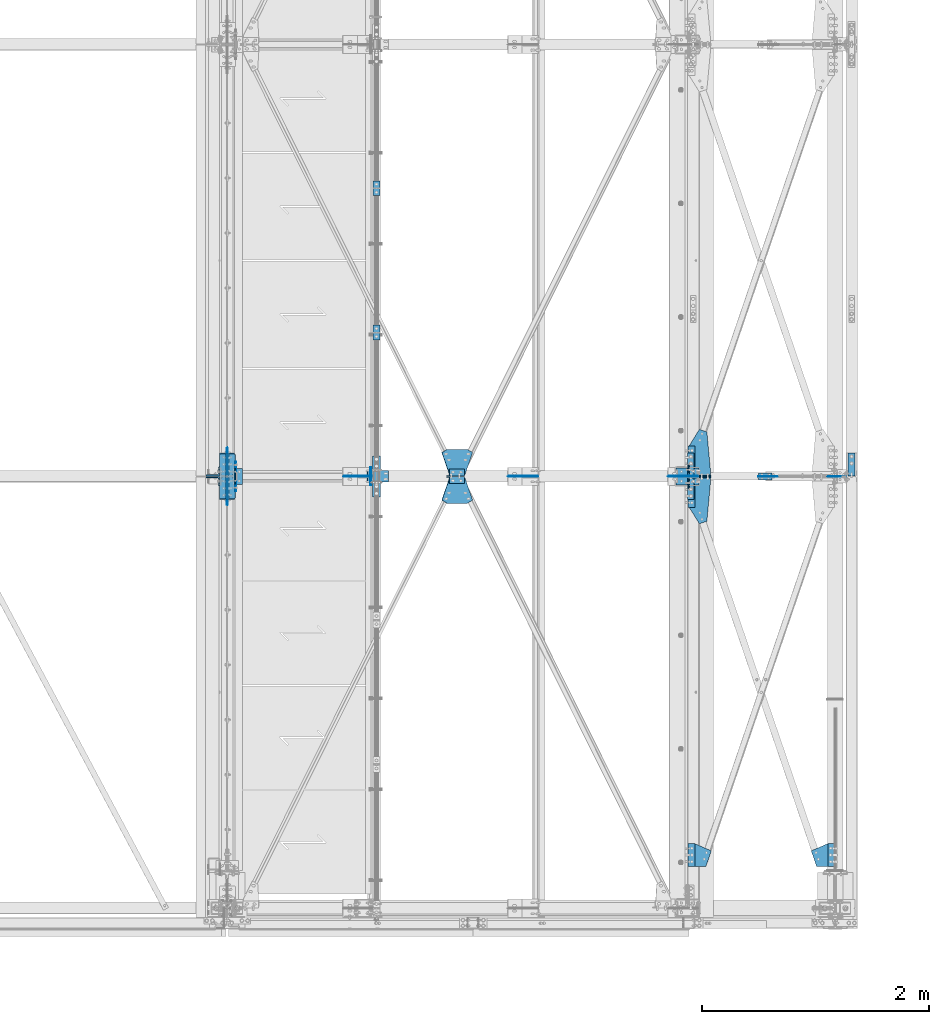
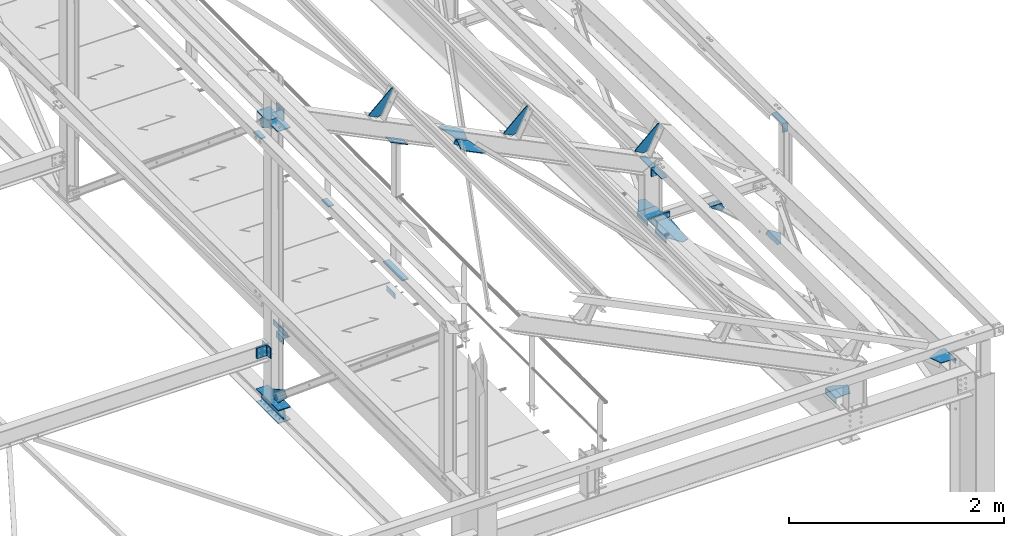
# One storey, part 106 of 496: 34 beams, 7 members, 32 elements without a shape of their own.
"""IFC2X3 building model written with IfcOpenShell, lengths in millimetres."""

from ifc_helpers import new_model, si_unit, frame, frame_2d, origin_with_axes, origin_2d_with_axis, place, context, subcontext, project, spatial, polyline, circle_curve, parameter, trimmed, segment, composite_curve, rectangle, l_section, outline, extrude, material, type_object, element, aggregate, save


model = new_model("IFC2X3")

# Units and contexts
model_context = context("Model", 3, precision=1e-05, world=origin_with_axes())
body_context = subcontext(model_context, "Body", "Model", "MODEL_VIEW")
ifc_project = project(units=[si_unit("LENGTHUNIT", "METRE", prefix="MILLI"), si_unit("AREAUNIT", "SQUARE_METRE"), si_unit("VOLUMEUNIT", "CUBIC_METRE"), si_unit("MASSUNIT", "GRAM", prefix="KILO"), si_unit("TIMEUNIT", "SECOND"), si_unit("PLANEANGLEUNIT", "RADIAN"), si_unit("SOLIDANGLEUNIT", "STERADIAN"), si_unit("THERMODYNAMICTEMPERATUREUNIT", "DEGREE_CELSIUS"), si_unit("LUMINOUSINTENSITYUNIT", "LUMEN")], contexts=[model_context])

# Site, building, storey
site_placement = place(None, origin_with_axes())
site = spatial("IfcSite", under=ifc_project, at=site_placement, CompositionType="ELEMENT")
building_placement = place(site_placement, origin_with_axes())
building = spatial("IfcBuilding", under=site, at=building_placement, Name="Undefined", CompositionType="ELEMENT")
storey_placement = place(building_placement, origin_with_axes())
storey = spatial("IfcBuildingStorey", under=building, at=storey_placement, Name="Undefined", CompositionType="ELEMENT", Elevation=0.0)

# Assembly, beams
assembly_1_placement = place(storey_placement, origin_with_axes())
assembly_1 = element("IfcElementAssembly", 1, at=assembly_1_placement, inside=storey, Name="MAIN COURANTE", AssemblyPlace="NOTDEFINED", PredefinedType="NOTDEFINED")
ifc_material = material(Name="Undefined/S235-E24")
beam_type_1 = type_object("IfcBeamType", PredefinedType="NOTDEFINED")
beam_1_placement = place(assembly_1_placement, frame((35593.9917151013, 5130.00343196824, 8245.00000549095), z_axis=(-1.0, 0.0, 0.0), x_axis=(0.0, -1.0, 0.0)))
beam_1 = element("IfcBeam", 2, at=beam_1_placement, type_object=beam_type_1, material=ifc_material, context=body_context, shape_type="SweptSolid", body=[
    extrude(rectangle(XDim=10.0, YDim=60.0, at=origin_2d_with_axis()), frame((130.0, 0.0, 0.0), z_axis=(-1.0, 0.0, 0.0), x_axis=(0.0, -1.0, 0.0)), (0.0, 0.0, 1.0), 130.0),
])
beam_2_placement = place(assembly_1_placement, frame((35593.9917161564, 6400.00343196824, 8245.00000462038), z_axis=(-1.0, 0.0, 0.0), x_axis=(0.0, -1.0, 0.0)))
beam_2 = element("IfcBeam", 3, at=beam_2_placement, type_object=beam_type_1, material=ifc_material, context=body_context, shape_type="SweptSolid", body=[
    extrude(rectangle(XDim=10.0, YDim=60.0, at=origin_2d_with_axis()), frame((130.0, 0.0, 0.0), z_axis=(-1.0, 0.0, 0.0), x_axis=(0.0, -1.0, 0.0)), (0.0, 0.0, 1.0), 130.0),
])
aggregate(assembly_1, [beam_1, beam_2])

# Assembly, beam
assembly_2_placement = place(storey_placement, origin_with_axes())
assembly_2 = element("IfcElementAssembly", 4, at=assembly_2_placement, inside=storey, AssemblyPlace="NOTDEFINED", PredefinedType="NOTDEFINED")
beam_type_2 = type_object("IfcBeamType", PredefinedType="NOTDEFINED")
beam_3_placement = place(assembly_2_placement, frame((39594.9999999988, 366.801988897695, 7882.39566743768), z_axis=(0.0, -0.031410887010906, -0.999506556345274), x_axis=(0.0, 0.999506556345274, -0.0314108870109058)))
beam_3 = element("IfcBeam", 5, at=beam_3_placement, type_object=beam_type_2, material=ifc_material, context=body_context, shape_type="SweptSolid", body=[
    extrude(l_section(Depth=60.0, Width=60.0, Thickness=6.0, FilletRadius=8.0, EdgeRadius=4.0, at=origin_2d_with_axis()), frame((200.0, 0.0, 0.0), z_axis=(-1.0, 0.0, 0.0), x_axis=(0.0, -1.0, 0.0)), (0.0, 0.0, 1.0), 200.0),
])
aggregate(assembly_2, [beam_3])

assembly_3_placement = place(storey_placement, origin_with_axes())
assembly_3 = element("IfcElementAssembly", 6, at=assembly_3_placement, inside=storey, AssemblyPlace="NOTDEFINED", PredefinedType="NOTDEFINED")
beam_4_placement = place(assembly_3_placement, frame((38365.0000000024, 566.703299806068, 7876.11347890941), z_axis=(0.0, -0.031410887010906, -0.999506556345274), x_axis=(0.0, -0.999506556345276, 0.031410887010852)))
beam_4 = element("IfcBeam", 7, at=beam_4_placement, type_object=beam_type_2, material=ifc_material, context=body_context, shape_type="SweptSolid", body=[
    extrude(l_section(Depth=60.0, Width=60.0, Thickness=6.0, FilletRadius=8.0, EdgeRadius=4.0, at=origin_2d_with_axis()), frame((200.0, 0.0, 0.0), z_axis=(-1.0, 0.0, 0.0), x_axis=(0.0, -1.0, 0.0)), (0.0, 0.0, 1.0), 200.0),
])
aggregate(assembly_3, [beam_4])

assembly_4_placement = place(storey_placement, origin_with_axes())
assembly_4 = element("IfcElementAssembly", 8, at=assembly_4_placement, inside=storey, AssemblyPlace="NOTDEFINED", PredefinedType="NOTDEFINED")
beam_5_placement = place(assembly_4_placement, frame((38365.0000000024, 3727.01910135981, 7776.79665503846), z_axis=(0.0, -0.031410887010906, -0.999506556345274), x_axis=(0.0, -0.999506556345276, 0.031410887010852)))
beam_5 = element("IfcBeam", 9, at=beam_5_placement, type_object=beam_type_2, material=ifc_material, context=body_context, shape_type="SweptSolid", body=[
    extrude(l_section(Depth=60.0, Width=60.0, Thickness=6.0, FilletRadius=8.0, EdgeRadius=4.0, at=origin_2d_with_axis()), frame((200.0, 0.0, 0.0), z_axis=(-1.0, 0.0, 0.0), x_axis=(0.0, -1.0, 0.0)), (0.0, 0.0, 1.0), 200.0),
])
aggregate(assembly_4, [beam_5])

assembly_5_placement = place(storey_placement, origin_with_axes())
assembly_5 = element("IfcElementAssembly", 10, at=assembly_5_placement, inside=storey, AssemblyPlace="NOTDEFINED", PredefinedType="NOTDEFINED")
beam_6_placement = place(assembly_5_placement, frame((38365.0000000024, 4066.85133304005, 7766.11703371736), z_axis=(0.0, -0.031410887010906, -0.999506556345274), x_axis=(0.0, -0.999506556345276, 0.031410887010852)))
beam_6 = element("IfcBeam", 11, at=beam_6_placement, type_object=beam_type_2, material=ifc_material, context=body_context, shape_type="SweptSolid", body=[
    extrude(l_section(Depth=60.0, Width=60.0, Thickness=6.0, FilletRadius=8.0, EdgeRadius=4.0, at=origin_2d_with_axis()), frame((200.0, 0.0, 0.0), z_axis=(-1.0, 0.0, 0.0), x_axis=(0.0, -1.0, 0.0)), (0.0, 0.0, 1.0), 200.0),
])
aggregate(assembly_5, [beam_6])

assembly_6_placement = place(storey_placement, origin_with_axes())
assembly_6 = element("IfcElementAssembly", 12, at=assembly_6_placement, inside=storey, Name="TRAVERSE SHED", AssemblyPlace="NOTDEFINED", PredefinedType="NOTDEFINED")
beam_type_3 = type_object("IfcBeamType", PredefinedType="NOTDEFINED")
beam_7_placement = place(assembly_6_placement, frame((38330.0, 3874.80562184453, 7933.23320419234), z_axis=(-1.0, 0.0, 0.0), x_axis=(0.0, -0.999506556345276, 0.031410887010852)))
beam_7 = element("IfcBeam", 13, at=beam_7_placement, type_object=beam_type_3, material=ifc_material, context=body_context, shape_type="SweptSolid", body=[
    extrude(rectangle(XDim=10.0, YDim=200.0, at=origin_2d_with_axis()), frame((149.999995982835, 4.54747350886464e-12, 3.63797880709171e-12), z_axis=(-1.0, 0.0, 0.0), x_axis=(0.0, -1.0, 0.0)), (0.0, 0.0, 1.0), 150.0),
])

assembly_7_placement = place(storey_placement, origin_with_axes())
assembly_7 = element("IfcElementAssembly", 14, at=assembly_7_placement, inside=storey, AssemblyPlace="NOTDEFINED", PredefinedType="NOTDEFINED")
beam_type_4 = type_object("IfcBeamType", PredefinedType="NOTDEFINED")
beam_8_placement = place(assembly_7_placement, frame((34381.5001146478, 3730.0, 7915.0), z_axis=(1.0, 0.0, 0.0), x_axis=(0.0, 1.0, 0.0)))
beam_8 = element("IfcBeam", 15, at=beam_8_placement, type_object=beam_type_4, material=ifc_material, context=body_context, shape_type="SweptSolid", body=[
    extrude(l_section(Depth=70.0, Width=70.0, Thickness=7.0, FilletRadius=9.0, EdgeRadius=4.5, at=origin_2d_with_axis()), frame((140.0, 0.0, 0.0), z_axis=(-1.0, 0.0, 0.0), x_axis=(0.0, -1.0, 0.0)), (0.0, 0.0, 1.0), 140.0),
])
aggregate(assembly_7, [beam_8])

# Assembly, member
assembly_8_placement = place(storey_placement, origin_with_axes())
assembly_8 = element("IfcElementAssembly", 16, at=assembly_8_placement, inside=storey, AssemblyPlace="NOTDEFINED", PredefinedType="NOTDEFINED")
member_type_1 = type_object("IfcMemberType", PredefinedType="NOTDEFINED")
member_1_placement = place(assembly_8_placement, frame((36221.8078763845, 3767.00045409889, 9484.14531737299), z_axis=(0.0, -1.0, 0.0), x_axis=(0.897398510539058, 0.0, -0.441220934773362)))
member_1 = element("IfcMember", 17, at=member_1_placement, type_object=member_type_1, material=ifc_material, context=body_context, shape_type="SweptSolid", body=[
    extrude(l_section(Depth=60.0, Width=60.0, Thickness=6.0, FilletRadius=8.0, EdgeRadius=4.0, at=origin_2d_with_axis()), frame((149.999995982835, 4.54747350886464e-12, 3.63797880709171e-12), z_axis=(-1.0, 0.0, 0.0), x_axis=(0.0, -1.0, 0.0)), (0.0, 0.0, 1.0), 150.0),
])
aggregate(assembly_8, [member_1])

assembly_9_placement = place(storey_placement, origin_with_axes())
assembly_9 = element("IfcElementAssembly", 18, at=assembly_9_placement, inside=storey, AssemblyPlace="NOTDEFINED", PredefinedType="NOTDEFINED")
member_2_placement = place(assembly_9_placement, frame((36356.4176224926, 3833.00025093933, 9417.96211720239), z_axis=(0.0, 1.0, 0.0), x_axis=(-0.897398510539055, -1.29999898490537e-08, 0.441220934773368)))
member_2 = element("IfcMember", 19, at=member_2_placement, type_object=member_type_1, material=ifc_material, context=body_context, shape_type="SweptSolid", body=[
    extrude(l_section(Depth=60.0, Width=60.0, Thickness=6.0, FilletRadius=8.0, EdgeRadius=4.0, at=origin_2d_with_axis()), frame((149.999995982835, 4.54747350886464e-12, 3.63797880709171e-12), z_axis=(-1.0, 0.0, 0.0), x_axis=(0.0, -1.0, 0.0)), (0.0, 0.0, 1.0), 150.0),
])
aggregate(assembly_9, [member_2])

# Assembly, beam
assembly_10_placement = place(storey_placement, origin_with_axes())
assembly_10 = element("IfcElementAssembly", 20, at=assembly_10_placement, inside=storey, Name="SHED", AssemblyPlace="NOTDEFINED", PredefinedType="NOTDEFINED")
beam_type_5 = type_object("IfcBeamType", PredefinedType="NOTDEFINED")
beam_9_placement = place(assembly_10_placement, frame((38167.3881652729, 3800.0, 8712.54750741415), z_axis=(0.0, -1.0, 0.0), x_axis=(-0.441220935974661, 0.0, -0.89739850994842)))
beam_9 = element("IfcBeam", 21, at=beam_9_placement, type_object=beam_type_5, material=ifc_material, context=body_context, shape_type="SweptSolid", body=[
    extrude(outline(polyline([(0.0, 0.0), (20.0, 0.0), (20.0000000002019, 109.999999999982), (-9.99999999974731, 139.99998998623), (-300.0000000002, 139.999893186625), (-300.000000000226, 119.999893186643), (0.0, 0.0)])), frame((0.0, 0.0, -4.0), z_axis=(0.0, 0.0, 1.0), x_axis=(1.0, 0.0, 0.0)), (0.0, 0.0, 1.0), 8.0),
])
aggregate(assembly_10, [beam_9])

assembly_11_placement = place(storey_placement, origin_with_axes())
assembly_11 = element("IfcElementAssembly", 22, at=assembly_11_placement, inside=storey, Name="SHED", AssemblyPlace="NOTDEFINED", PredefinedType="NOTDEFINED")
beam_10_placement = place(assembly_11_placement, frame((36758.937741054, 3800.0, 9405.03563331224), z_axis=(0.0, -1.0, 0.0), x_axis=(-0.441220935974661, 0.0, -0.89739850994842)))
beam_10 = element("IfcBeam", 23, at=beam_10_placement, type_object=beam_type_5, material=ifc_material, context=body_context, shape_type="SweptSolid", body=[
    extrude(outline(polyline([(0.0, 0.0), (20.0, 0.0), (20.0000000002019, 109.999999999982), (-9.99999999974731, 139.99998998623), (-300.0000000002, 139.999893186625), (-300.000000000226, 119.999893186643), (0.0, 0.0)])), frame((0.0, 0.0, -4.0), z_axis=(0.0, 0.0, 1.0), x_axis=(1.0, 0.0, 0.0)), (0.0, 0.0, 1.0), 8.0),
])
aggregate(assembly_11, [beam_10])

assembly_12_placement = place(storey_placement, origin_with_axes())
assembly_12 = element("IfcElementAssembly", 24, at=assembly_12_placement, inside=storey, Name="SHED", AssemblyPlace="NOTDEFINED", PredefinedType="NOTDEFINED")
beam_11_placement = place(assembly_12_placement, frame((35310.1044072469, 3800.0, 10117.3786897729), z_axis=(0.0, -1.0, 0.0), x_axis=(-0.441220935974661, 0.0, -0.89739850994842)))
beam_11 = element("IfcBeam", 25, at=beam_11_placement, type_object=beam_type_5, material=ifc_material, context=body_context, shape_type="SweptSolid", body=[
    extrude(outline(polyline([(0.0, 0.0), (20.0, 0.0), (20.0000000002019, 109.999999999982), (-9.99999999974731, 139.99998998623), (-300.0000000002, 139.999893186625), (-300.000000000226, 119.999893186643), (0.0, 0.0)])), frame((0.0, 0.0, -4.0), z_axis=(0.0, 0.0, 1.0), x_axis=(1.0, 0.0, 0.0)), (0.0, 0.0, 1.0), 8.0),
])
aggregate(assembly_12, [beam_11])

assembly_13_placement = place(storey_placement, origin_with_axes())
assembly_13 = element("IfcElementAssembly", 26, at=assembly_13_placement, inside=storey, AssemblyPlace="NOTDEFINED", PredefinedType="NOTDEFINED")
beam_type_6 = type_object("IfcBeamType", PredefinedType="NOTDEFINED")
beam_12_placement = place(assembly_13_placement, frame((38343.50000391, 567.739859850852, 7909.09719393175), z_axis=(1.303644888773e-06, -0.0314106010104438, -0.999506565332346), x_axis=(0.99999999999915, 4.09999990805545e-08, 1.30299999953106e-06)))
beam_12 = element("IfcBeam", 27, at=beam_12_placement, type_object=beam_type_6, material=ifc_material, context=body_context, shape_type="SweptSolid", body=[
    extrude(outline(polyline([(0.0, 0.0), (51.5000038159342, -1.75987224793062e-10), (196.831817628714, 63.0573387138022), (150.006042481553, 199.99999999939), (-0.000139138632221147, 199.999999999997), (0.0, 0.0)])), frame((0.0, 0.0, -3.0), z_axis=(0.0, 0.0, 1.0), x_axis=(1.0, 0.0, 0.0)), (0.0, 0.0, 1.0), 6.0),
])
aggregate(assembly_13, [beam_12])

assembly_14_placement = place(storey_placement, origin_with_axes())
assembly_14 = element("IfcElementAssembly", 28, at=assembly_14_placement, inside=storey, AssemblyPlace="NOTDEFINED", PredefinedType="NOTDEFINED")
beam_13_placement = place(assembly_14_placement, frame((39616.49999609, 567.739859850562, 7909.09719393176), z_axis=(1.30364488877521e-06, 0.0314106010104438, 0.999506565332346), x_axis=(-0.99999999999915, 4.0999999080624e-08, 1.30299999953327e-06)))
beam_13 = element("IfcBeam", 29, at=beam_13_placement, type_object=beam_type_6, material=ifc_material, context=body_context, shape_type="SweptSolid", body=[
    extrude(outline(polyline([(0.0, 0.0), (51.5000038159342, -1.75987224793062e-10), (196.831817628714, 63.0573387138022), (150.006042481553, 199.99999999939), (-0.000139138632221147, 199.999999999997), (0.0, 0.0)])), frame((0.0, 0.0, -3.0), z_axis=(0.0, 0.0, 1.0), x_axis=(1.0, 0.0, 0.0)), (0.0, 0.0, 1.0), 6.0),
])
aggregate(assembly_14, [beam_13])

# Assembly, member
assembly_15_placement = place(storey_placement, origin_with_axes())
assembly_15 = element("IfcElementAssembly", 30, at=assembly_15_placement, inside=storey, AssemblyPlace="NOTDEFINED", PredefinedType="NOTDEFINED")
member_type_2 = type_object("IfcMemberType", PredefinedType="NOTDEFINED")
member_3_placement = place(assembly_15_placement, frame((38435.0, 3851.71823980771, 7828.90545117255), z_axis=(1.0, 0.0, 0.0), x_axis=(0.0, 0.031410887010906, 0.999506556345274)))
member_3 = element("IfcMember", 31, at=member_3_placement, type_object=member_type_2, material=ifc_material, context=body_context, shape_type="SweptSolid", body=[
    extrude(l_section(Depth=200.0, Width=100.0, Thickness=10.0, FilletRadius=15.0, EdgeRadius=7.5, at=origin_2d_with_axis()), frame((60.0, 0.0, 0.0), z_axis=(-1.0, 0.0, 0.0), x_axis=(0.0, -1.0, 0.0)), (0.0, 0.0, 1.0), 60.0),
])
aggregate(assembly_15, [member_3])

assembly_16_placement = place(storey_placement, origin_with_axes())
assembly_16 = element("IfcElementAssembly", 32, at=assembly_16_placement, inside=storey, AssemblyPlace="NOTDEFINED", PredefinedType="NOTDEFINED")
member_4_placement = place(assembly_16_placement, frame((38435.0000000001, 3747.65438168297, 7892.20549823504), z_axis=(1.0, 0.0, 0.0), x_axis=(0.0, -0.031410887010906, -0.999506556345274)))
member_4 = element("IfcMember", 33, at=member_4_placement, type_object=member_type_2, material=ifc_material, context=body_context, shape_type="SweptSolid", body=[
    extrude(l_section(Depth=200.0, Width=100.0, Thickness=10.0, FilletRadius=15.0, EdgeRadius=7.5, at=origin_2d_with_axis()), frame((60.0, 0.0, 0.0), z_axis=(-1.0, 0.0, 0.0), x_axis=(0.0, -1.0, 0.0)), (0.0, 0.0, 1.0), 60.0),
])
aggregate(assembly_16, [member_4])

# Assembly, beam
assembly_17_placement = place(storey_placement, origin_with_axes())
assembly_17 = element("IfcElementAssembly", 34, at=assembly_17_placement, inside=storey, AssemblyPlace="NOTDEFINED", PredefinedType="NOTDEFINED")
beam_type_7 = type_object("IfcBeamType", PredefinedType="NOTDEFINED")
beam_14_placement = place(assembly_17_placement, frame((34280.0, 4005.00000000017, 7112.0000000001), z_axis=(1.0, 0.0, 0.0), x_axis=(0.0, -1.0, 0.0)))
beam_14 = element("IfcBeam", 35, at=beam_14_placement, type_object=beam_type_7, material=ifc_material, context=body_context, shape_type="SweptSolid", body=[
    extrude(rectangle(XDim=10.0, YDim=133.0, at=origin_2d_with_axis()), frame((410.0, 0.0, 0.0), z_axis=(-1.0, 0.0, 0.0), x_axis=(0.0, -1.0, 0.0)), (0.0, 0.0, 1.0), 410.0),
])
aggregate(assembly_17, [beam_14])

assembly_18_placement = place(storey_placement, origin_with_axes())
assembly_18 = element("IfcElementAssembly", 36, at=assembly_18_placement, inside=storey, Name="MONTANT", AssemblyPlace="NOTDEFINED", PredefinedType="NOTDEFINED")
beam_15_placement = place(assembly_18_placement, frame((34280.0, 4005.00000000017, 7255.0000000001), z_axis=(1.0, 0.0, 0.0), x_axis=(0.0, -1.0, 0.0)))
beam_15 = element("IfcBeam", 37, at=beam_15_placement, type_object=beam_type_7, material=ifc_material, context=body_context, shape_type="SweptSolid", body=[
    extrude(rectangle(XDim=10.0, YDim=133.0, at=origin_2d_with_axis()), frame((410.0, 0.0, 0.0), z_axis=(-1.0, 0.0, 0.0), x_axis=(0.0, -1.0, 0.0)), (0.0, 0.0, 1.0), 410.0),
])

assembly_19_placement = place(storey_placement, origin_with_axes())
assembly_19 = element("IfcElementAssembly", 38, at=assembly_19_placement, inside=storey, AssemblyPlace="NOTDEFINED", PredefinedType="NOTDEFINED")
beam_type_8 = type_object("IfcBeamType", PredefinedType="NOTDEFINED")
beam_16_placement = place(assembly_19_placement, frame((39805.0, 3903.5, 8400.0), z_axis=(0.0, 1.0, 0.0), x_axis=(-1.0, 0.0, 0.0)))
beam_16 = element("IfcBeam", 39, at=beam_16_placement, type_object=beam_type_8, material=ifc_material, context=body_context, shape_type="SweptSolid", body=[
    extrude(l_section(Depth=200.0, Width=100.0, Thickness=10.0, FilletRadius=15.0, EdgeRadius=7.5, at=origin_2d_with_axis()), frame((60.0, 0.0, 0.0), z_axis=(-1.0, 0.0, 0.0), x_axis=(0.0, -1.0, 0.0)), (0.0, 0.0, 1.0), 60.0),
])
aggregate(assembly_19, [beam_16])

assembly_20_placement = place(storey_placement, origin_with_axes())
assembly_20 = element("IfcElementAssembly", 40, at=assembly_20_placement, inside=storey, AssemblyPlace="NOTDEFINED", PredefinedType="NOTDEFINED")
beam_17_placement = place(assembly_20_placement, frame((38390.0, 3903.5, 8400.0), z_axis=(0.0, 1.0, 0.0), x_axis=(-1.0, 0.0, 0.0)))
beam_17 = element("IfcBeam", 41, at=beam_17_placement, type_object=beam_type_8, material=ifc_material, context=body_context, shape_type="SweptSolid", body=[
    extrude(l_section(Depth=200.0, Width=100.0, Thickness=10.0, FilletRadius=15.0, EdgeRadius=7.5, at=origin_2d_with_axis()), frame((60.0, 0.0, 0.0), z_axis=(-1.0, 0.0, 0.0), x_axis=(0.0, -1.0, 0.0)), (0.0, 0.0, 1.0), 60.0),
])
aggregate(assembly_20, [beam_17])

assembly_21_placement = place(storey_placement, origin_with_axes())
assembly_21 = element("IfcElementAssembly", 42, at=assembly_21_placement, inside=storey, AssemblyPlace="NOTDEFINED", PredefinedType="NOTDEFINED")
beam_18_placement = place(assembly_21_placement, frame((38330.0, 3696.5, 8400.0), z_axis=(0.0, -1.0, 0.0), x_axis=(1.0, 0.0, 0.0)))
beam_18 = element("IfcBeam", 43, at=beam_18_placement, type_object=beam_type_8, material=ifc_material, context=body_context, shape_type="SweptSolid", body=[
    extrude(l_section(Depth=200.0, Width=100.0, Thickness=10.0, FilletRadius=15.0, EdgeRadius=7.5, at=origin_2d_with_axis()), frame((60.0, 0.0, 0.0), z_axis=(-1.0, 0.0, 0.0), x_axis=(0.0, -1.0, 0.0)), (0.0, 0.0, 1.0), 60.0),
])
aggregate(assembly_21, [beam_18])

# Assembly, member
assembly_22_placement = place(storey_placement, origin_with_axes())
assembly_22 = element("IfcElementAssembly", 44, at=assembly_22_placement, inside=storey, AssemblyPlace="NOTDEFINED", PredefinedType="NOTDEFINED")
member_type_3 = type_object("IfcMemberType", PredefinedType="NOTDEFINED")
member_5_placement = place(assembly_22_placement, frame((35511.0197434437, 3800.00000001334, 9756.72720417295), z_axis=(0.0, -1.0, 0.0), x_axis=(0.897398510539058, 0.0, -0.441220934773362)))
member_5 = element("IfcMember", 45, at=member_5_placement, type_object=member_type_3, material=ifc_material, context=body_context, shape_type="SweptSolid", body=[
    extrude(rectangle(XDim=10.0, YDim=100.0, at=origin_2d_with_axis()), frame((210.000000000491, 0.0, 1.81898940354586e-12), z_axis=(-1.0, 0.0, 0.0), x_axis=(0.0, -1.0, 0.0)), (0.0, 0.0, 1.0), 210.0),
])

# Assembly, beams
assembly_23_placement = place(storey_placement, origin_with_axes())
assembly_23 = element("IfcElementAssembly", 46, at=assembly_23_placement, inside=storey, AssemblyPlace="NOTDEFINED", PredefinedType="NOTDEFINED")
beam_type_9 = type_object("IfcBeamType", PredefinedType="NOTDEFINED")
beam_19_placement = place(assembly_23_placement, frame((35542.9917140619, 3720.0, 7985.0), z_axis=(-1.0, 0.0, 0.0), x_axis=(0.0, 0.0, 1.0)))
beam_19 = element("IfcBeam", 47, at=beam_19_placement, type_object=beam_type_9, material=ifc_material, context=body_context, shape_type="SweptSolid", body=[
    extrude(outline(polyline([(0.0, 0.0), (60.0, 0.0), (60.0, 159.999984741211), (0.0, 159.999984741211), (0.0, 0.0)])), frame((0.0, 0.0, -3.0), z_axis=(0.0, 0.0, 1.0), x_axis=(1.0, 0.0, 0.0)), (0.0, 0.0, 1.0), 6.0),
])
beam_20_placement = place(assembly_23_placement, frame((34354.991943003, 3670.0, 7985.0), z_axis=(-1.0, 0.0, 0.0), x_axis=(0.0, 0.0, 1.0)))
beam_20 = element("IfcBeam", 48, at=beam_20_placement, type_object=beam_type_9, material=ifc_material, context=body_context, shape_type="SweptSolid", body=[
    extrude(outline(polyline([(0.0, 0.0), (60.0, 0.0), (60.0, 260.0), (0.0, 260.0), (0.0, 0.0)])), frame((0.0, 0.0, -3.0), z_axis=(0.0, 0.0, 1.0), x_axis=(1.0, 0.0, 0.0)), (0.0, 0.0, 1.0), 6.0),
])
aggregate(assembly_23, [beam_19, beam_20])

# Beam
beam_type_10 = type_object("IfcBeamType", PredefinedType="NOTDEFINED")
beam_21_placement = place(assembly_22_placement, frame((35593.9917140619, 3980.00010616247, 8245.00000367738), z_axis=(1.0, 0.0, 0.0), x_axis=(0.0, -1.0, 0.0)))
beam_21 = element("IfcBeam", 49, at=beam_21_placement, type_object=beam_type_10, material=ifc_material, context=body_context, shape_type="SweptSolid", body=[
    extrude(rectangle(XDim=10.0, YDim=70.0, at=origin_2d_with_axis()), frame((360.000000000004, 0.0, 0.0), z_axis=(-1.0, 0.0, 0.0), x_axis=(0.0, -1.0, 0.0)), (0.0, 0.0, 1.0), 360.0),
])

aggregate(assembly_22, [member_5, beam_21])

beam_type_11 = type_object("IfcBeamType", PredefinedType="NOTDEFINED")
beam_22_placement = place(assembly_6_placement, frame((34351.5, 3800.0, 10548.0682550821), z_axis=(0.0, -1.0, 0.0), x_axis=(0.0, 0.0, -1.0)))
beam_22 = element("IfcBeam", 50, at=beam_22_placement, type_object=beam_type_11, material=ifc_material, context=body_context, shape_type="SweptSolid", body=[
    extrude(rectangle(XDim=10.0, YDim=140.0, at=origin_2d_with_axis()), frame((213.394604237721, 0.0, 0.0), z_axis=(-1.0, 0.0, 0.0), x_axis=(0.0, -1.0, 0.0)), (0.0, 0.0, 1.0), 213.39),
])

aggregate(assembly_6, [beam_7, beam_22])

# Assembly, beam
assembly_24_placement = place(storey_placement, origin_with_axes())
assembly_24 = element("IfcElementAssembly", 51, at=assembly_24_placement, inside=storey, AssemblyPlace="NOTDEFINED", PredefinedType="NOTDEFINED")
beam_type_12 = type_object("IfcBeamType", PredefinedType="NOTDEFINED")
beam_23_placement = place(assembly_24_placement, frame((36370.9779523025, 3813.00015384202, 9447.57632338533), z_axis=(-0.441220935974661, 0.0, -0.89739850994842), x_axis=(-0.897398510539055, -1.29999898490537e-08, 0.441220934773368)))
beam_23 = element("IfcBeam", 52, at=beam_23_placement, type_object=beam_type_12, material=ifc_material, context=body_context, shape_type="SweptSolid", body=[
    extrude(outline(polyline([(0.0, 0.0), (149.999999999138, -4.0381564758718e-10), (225.299438472997, 196.258819581493), (172.823120113848, 225.348953248153), (-22.830436708522, 225.348953246928), (-75.3067550673877, 196.258804320814), (0.0, 0.0)])), frame((0.0, 0.0, -3.0), z_axis=(0.0, 0.0, 1.0), x_axis=(1.0, 0.0, 0.0)), (0.0, 0.0, 1.0), 6.0),
])
aggregate(assembly_24, [beam_23])

assembly_25_placement = place(storey_placement, origin_with_axes())
assembly_25 = element("IfcElementAssembly", 53, at=assembly_25_placement, inside=storey, AssemblyPlace="NOTDEFINED", PredefinedType="NOTDEFINED")
beam_24_placement = place(assembly_25_placement, frame((36370.9779526953, 3787.00055704746, 9447.57632338629), z_axis=(0.441221071222121, 0.0, 0.897398443451739), x_axis=(-0.897398510539055, -1.29999898490537e-08, 0.441220934773368)))
beam_24 = element("IfcBeam", 54, at=beam_24_placement, type_object=beam_type_12, material=ifc_material, context=body_context, shape_type="SweptSolid", body=[
    extrude(outline(polyline([(0.0, 0.0), (149.999999999138, -4.0381564758718e-10), (225.299438472997, 196.258819581493), (172.823120113848, 225.348953248153), (-22.830436708522, 225.348953246928), (-75.3067550673877, 196.258804320814), (0.0, 0.0)])), frame((0.0, 0.0, -3.0), z_axis=(0.0, 0.0, 1.0), x_axis=(1.0, 0.0, 0.0)), (0.0, 0.0, 1.0), 6.0),
])
aggregate(assembly_25, [beam_24])

# Assembly, beams
assembly_26_placement = place(storey_placement, origin_with_axes())
assembly_26 = element("IfcElementAssembly", 55, at=assembly_26_placement, inside=storey, AssemblyPlace="NOTDEFINED", PredefinedType="NOTDEFINED")
beam_type_13 = type_object("IfcBeamType", PredefinedType="NOTDEFINED")
beam_25_placement = place(assembly_26_placement, frame((39015.0, 3830.00533210934, 7806.57650937342), z_axis=(1.0, 0.0, 0.0), x_axis=(0.0, -0.999506556345276, 0.031410887010852)))
beam_25 = element("IfcBeam", 56, at=beam_25_placement, type_object=beam_type_13, material=ifc_material, context=body_context, shape_type="SweptSolid", body=[
    extrude(rectangle(XDim=6.0, YDim=120.0, at=origin_2d_with_axis()), frame((63.999999999927, 0.0, 0.0), z_axis=(-1.0, 0.0, 0.0), x_axis=(0.0, -1.0, 0.0)), (0.0, 0.0, 1.0), 64.0),
])
beam_type_14 = type_object("IfcBeamType", PredefinedType="NOTDEFINED")
beam_26_placement = place(assembly_26_placement, frame((38955.0, 3798.12, 7804.42370507337), z_axis=(0.0, -1.0, 0.0), x_axis=(0.0, 0.0, -1.0)))
beam_26 = element("IfcBeam", 57, at=beam_26_placement, type_object=beam_type_14, material=ifc_material, context=body_context, shape_type="SweptSolid", body=[
    extrude(outline(polyline([(0.0, 0.0), (24.9957141876221, 0.0), (112.824180603027, 134.777084350586), (75.6574859619141, 168.223098754883), (-2.37123549595708e-06, 120.0), (0.0, 0.0)])), frame((0.0, 0.0, -3.0), z_axis=(0.0, 0.0, 1.0), x_axis=(1.0, 0.0, 0.0)), (0.0, 0.0, 1.0), 6.0),
])
aggregate(assembly_26, [beam_26, beam_25])

# Assembly, beam
assembly_27_placement = place(storey_placement, origin_with_axes())
assembly_27 = element("IfcElementAssembly", 58, at=assembly_27_placement, inside=storey, AssemblyPlace="NOTDEFINED", PredefinedType="NOTDEFINED")
beam_type_15 = type_object("IfcBeamType", PredefinedType="NOTDEFINED")
beam_27_placement = place(assembly_27_placement, frame((39562.2651636224, 3800.0, 7266.41114294544), z_axis=(0.0, -1.0, 0.0), x_axis=(0.605878052927936, 0.0, -0.795557530905373)))
beam_27 = element("IfcBeam", 59, at=beam_27_placement, type_object=beam_type_15, material=ifc_material, context=body_context, shape_type="SweptSolid", body=[
    extrude(outline(polyline([(0.0, 0.0), (209.175491333335, -5.74800651520491e-10), (233.410614014192, 31.8223018639765), (137.943710327876, 104.52766418417), (-9.30403423287135, 49.1267242431786), (0.0, 0.0)])), frame((0.0, 0.0, -3.0), z_axis=(0.0, 0.0, 1.0), x_axis=(1.0, 0.0, 0.0)), (0.0, 0.0, 1.0), 6.0),
])
aggregate(assembly_27, [beam_27])

assembly_28_placement = place(storey_placement, origin_with_axes())
assembly_28 = element("IfcElementAssembly", 60, at=assembly_28_placement, inside=storey, AssemblyPlace="NOTDEFINED", PredefinedType="NOTDEFINED")
beam_type_16 = type_object("IfcBeamType", PredefinedType="NOTDEFINED")
beam_28_placement = place(assembly_28_placement, frame((38435.27153336, 4213.86040001055, 7794.51337791392), z_axis=(0.0, 0.031410887010906, 0.999506556345274), x_axis=(-0.525777576315004, -0.850202359509391, 0.0267186850160107)))
beam_28 = element("IfcBeam", 61, at=beam_28_placement, type_object=beam_type_16, material=ifc_material, context=body_context, shape_type="SweptSolid", body=[
    extrude(outline(polyline([(0.0, 0.0), (171.691482542901, -6.18456397205591e-10), (631.027404784203, 283.919891356549), (707.794799803447, 437.494689941592), (653.704956053207, 481.927673340775), (328.681610105767, 320.40301513793), (274.241790769818, 286.753265382064), (-15.5598268524991, 68.2487487800354), (0.0, 0.0)])), frame((0.0, 0.0, -3.0), z_axis=(0.0, 0.0, 1.0), x_axis=(1.0, 0.0, 0.0)), (0.0, 0.0, 1.0), 6.0),
])
aggregate(assembly_28, [beam_28])

# Assembly, member
assembly_29_placement = place(storey_placement, origin_with_axes())
assembly_29 = element("IfcElementAssembly", 62, at=assembly_29_placement, inside=storey, AssemblyPlace="NOTDEFINED", PredefinedType="NOTDEFINED")
member_type_4 = type_object("IfcMemberType", PredefinedType="NOTDEFINED")
member_6_placement = place(assembly_29_placement, frame((34153.5000000005, 3844.86993296452, 7889.15200695419), z_axis=(-1.0, 0.0, 0.0), x_axis=(0.0, -0.031410887010906, -0.999506556345274)))
member_6 = element("IfcMember", 63, at=member_6_placement, type_object=member_type_4, material=ifc_material, context=body_context, shape_type="SweptSolid", body=[
    extrude(l_section(Depth=120.0, Width=80.0, Thickness=10.0, FilletRadius=11.0, EdgeRadius=5.5, at=origin_2d_with_axis()), frame((120.0, 0.0, 0.0), z_axis=(-1.0, 0.0, 0.0), x_axis=(0.0, -1.0, 0.0)), (0.0, 0.0, 1.0), 120.0),
])
aggregate(assembly_29, [member_6])

assembly_30_placement = place(storey_placement, origin_with_axes())
assembly_30 = element("IfcElementAssembly", 64, at=assembly_30_placement, inside=storey, AssemblyPlace="NOTDEFINED", PredefinedType="NOTDEFINED")
member_7_placement = place(assembly_30_placement, frame((34153.5000000006, 3755.14216198748, 7771.91261327797), z_axis=(-1.0, 0.0, 0.0), x_axis=(0.0, 0.031410887010906, 0.999506556345274)))
member_7 = element("IfcMember", 65, at=member_7_placement, type_object=member_type_4, material=ifc_material, context=body_context, shape_type="SweptSolid", body=[
    extrude(l_section(Depth=120.0, Width=80.0, Thickness=10.0, FilletRadius=11.0, EdgeRadius=5.5, at=origin_2d_with_axis()), frame((120.0, 0.0, 0.0), z_axis=(-1.0, 0.0, 0.0), x_axis=(0.0, -1.0, 0.0)), (0.0, 0.0, 1.0), 120.0),
])
aggregate(assembly_30, [member_7])

# Beam
beam_type_17 = type_object("IfcBeamType", PredefinedType="NOTDEFINED")
beam_29_placement = place(assembly_18_placement, frame((34280.0, 3802.75, 10413.0), z_axis=(-1.0, 0.0, 0.0), x_axis=(0.0, 1.0, 0.0)))
beam_29 = element("IfcBeam", 66, at=beam_29_placement, type_object=beam_type_17, material=ifc_material, context=body_context, shape_type="SweptSolid", body=[
    extrude(outline(polyline([(0.0, 20.0), (20.0, 0.0), (117.25, 0.0), (253.165084838867, 151.578048706055), (201.88996887207, 212.985397338867), (0.0, 100.0), (0.0, 20.0)])), frame((0.0, 0.0, -4.0), z_axis=(0.0, 0.0, 1.0), x_axis=(1.0, 0.0, 0.0)), (0.0, 0.0, 1.0), 8.0),
])

beam_type_18 = type_object("IfcBeamType", PredefinedType="NOTDEFINED")
beam_30_placement = place(assembly_18_placement, frame((34280.0, 3797.25, 7260.0), z_axis=(-1.0, 0.0, 0.0), x_axis=(0.0, -1.0, 0.0)))
beam_30 = element("IfcBeam", 67, at=beam_30_placement, type_object=beam_type_18, material=ifc_material, context=body_context, shape_type="SweptSolid", body=[
    extrude(outline(polyline([(0.0, 20.0), (20.0, 0.0), (97.25, 0.0), (253.164978027344, 151.578247070313), (201.889801025391, 212.985565185547), (0.0, 100.0), (0.0, 20.0)])), frame((0.0, 0.0, -4.0), z_axis=(0.0, 0.0, 1.0), x_axis=(1.0, 0.0, 0.0)), (0.0, 0.0, 1.0), 8.0),
])

beam_type_19 = type_object("IfcBeamType", PredefinedType="NOTDEFINED")
beam_31_placement = place(assembly_18_placement, frame((34213.5, 3604.99692211173, 10418.0), z_axis=(0.0, 0.0, -1.0), x_axis=(0.0, 1.0, 0.0)))
beam_31 = element("IfcBeam", 68, at=beam_31_placement, type_object=beam_type_19, material=ifc_material, Name="PLAT", context=body_context, shape_type="SweptSolid", body=[
    extrude(outline(composite_curve([segment(trimmed(circle_curve(frame_2d((10.0, 10.0), x_axis=(-1.0, 0.0)), 10.0), [parameter(0.0)], [parameter(1.5707963267949)], True, "PARAMETER"), True, "CONTINUOUS"), segment(polyline([(9.99999999997453, 6.91215973347425e-11), (124.5, 0.0), (124.5, 9.0), (172.25, 9.0), (192.25, 29.0), (192.25, 104.0), (172.25, 124.0), (124.0, 124.0), (124.0, 140.0), (10.0, 140.0)]), True, "CONTINUOUS"), segment(trimmed(circle_curve(frame_2d((10.0, 130.0), x_axis=(0.0, 1.0)), 10.0), [parameter(0.0)], [parameter(1.5707963267949)], True, "PARAMETER"), True, "CONTINUOUS"), segment(polyline([(0.0, 130.0), (-1.81898940354586e-10, 10.0000000000073)]), True, "CONTINUOUS")], self_intersect=True)), frame((0.0, 0.0, -5.0), z_axis=(0.0, 0.0, 1.0), x_axis=(1.0, 0.0, 0.0)), (0.0, 0.0, 1.0), 10.0),
])

beam_32_placement = place(assembly_18_placement, frame((34213.5, 3995.0, 10418.0), z_axis=(0.0, 0.0, 1.0), x_axis=(0.0, -1.0, 0.0)))
beam_32 = element("IfcBeam", 69, at=beam_32_placement, type_object=beam_type_19, material=ifc_material, Name="PLAT", context=body_context, shape_type="SweptSolid", body=[
    extrude(outline(composite_curve([segment(trimmed(circle_curve(frame_2d((10.0, 10.0), x_axis=(-1.0, 0.0)), 10.0), [parameter(0.0)], [parameter(1.5707963267949)], True, "PARAMETER"), True, "CONTINUOUS"), segment(polyline([(9.99999999997453, 6.91215973347425e-11), (124.5, 0.0), (124.5, 9.0), (172.25, 9.0), (192.25, 29.0), (192.25, 104.0), (172.25, 124.0), (124.0, 124.0), (124.0, 140.0), (10.0, 140.0)]), True, "CONTINUOUS"), segment(trimmed(circle_curve(frame_2d((10.0, 130.0), x_axis=(0.0, 1.0)), 10.0), [parameter(0.0)], [parameter(1.5707963267949)], True, "PARAMETER"), True, "CONTINUOUS"), segment(polyline([(0.0, 130.0), (-1.81898940354586e-10, 10.0000000000073)]), True, "CONTINUOUS")], self_intersect=True)), frame((0.0, 0.0, -5.0), z_axis=(0.0, 0.0, 1.0), x_axis=(1.0, 0.0, 0.0)), (0.0, 0.0, 1.0), 10.0),
])

aggregate(assembly_18, [beam_29, beam_30, beam_31, beam_32, beam_15])

# Assembly, beam
assembly_31_placement = place(storey_placement, origin_with_axes())
assembly_31 = element("IfcElementAssembly", 70, at=assembly_31_placement, inside=storey, AssemblyPlace="NOTDEFINED", PredefinedType="NOTDEFINED")
beam_type_20 = type_object("IfcBeamType", PredefinedType="NOTDEFINED")
beam_33_placement = place(assembly_31_placement, frame((34288.0, 4005.00000000017, 7183.5000000001), z_axis=(0.0, 0.0, -1.0), x_axis=(0.0, -1.0, 0.0)))
beam_33 = element("IfcBeam", 71, at=beam_33_placement, type_object=beam_type_20, material=ifc_material, context=body_context, shape_type="SweptSolid", body=[
    extrude(rectangle(XDim=10.0, YDim=90.0, at=origin_2d_with_axis()), frame((410.0, 0.0, 0.0), z_axis=(-1.0, 0.0, 0.0), x_axis=(0.0, -1.0, 0.0)), (0.0, 0.0, 1.0), 410.0),
])
aggregate(assembly_31, [beam_33])

assembly_32_placement = place(storey_placement, origin_with_axes())
assembly_32 = element("IfcElementAssembly", 72, at=assembly_32_placement, inside=storey, AssemblyPlace="NOTDEFINED", PredefinedType="NOTDEFINED")
beam_34_placement = place(assembly_32_placement, frame((34272.0, 4005.00000000017, 7183.5000000001), z_axis=(0.0, 0.0, -1.0), x_axis=(0.0, -1.0, 0.0)))
beam_34 = element("IfcBeam", 73, at=beam_34_placement, type_object=beam_type_20, material=ifc_material, context=body_context, shape_type="SweptSolid", body=[
    extrude(rectangle(XDim=10.0, YDim=90.0, at=origin_2d_with_axis()), frame((410.0, 0.0, 0.0), z_axis=(-1.0, 0.0, 0.0), x_axis=(0.0, -1.0, 0.0)), (0.0, 0.0, 1.0), 410.0),
])
aggregate(assembly_32, [beam_34])

save(model, "model.ifc")
